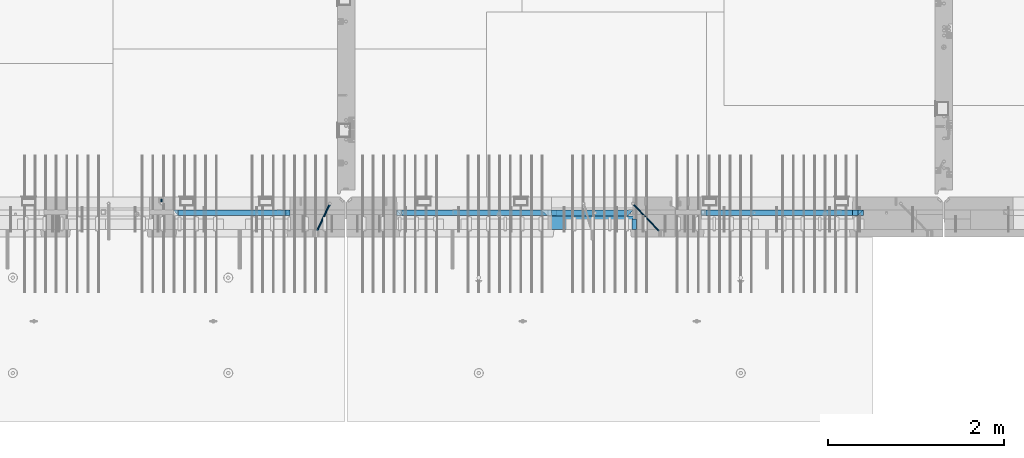
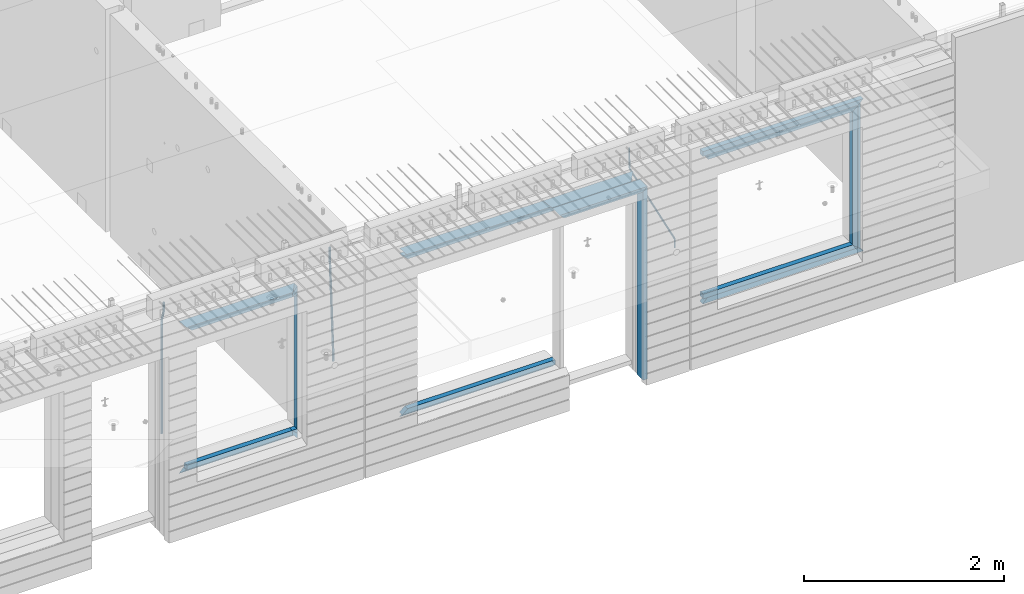
# One storey, part 80 of 309: 22 beams, 3 elements without a shape of their own.
"""IFC2X3 building model written with IfcOpenShell, lengths in millimetres."""

from ifc_helpers import new_model, si_unit, frame, origin_with_axes, place, context, subcontext, project, spatial, faceted_brep, material, type_object, element, aggregate, save


model = new_model("IFC2X3")

# Units and contexts
model_context = context("Model", 3, precision=1e-05, world=origin_with_axes())
body_context = subcontext(model_context, "Body", "Model", "MODEL_VIEW")
ifc_project = project(units=[si_unit("LENGTHUNIT", "METRE", prefix="MILLI"), si_unit("AREAUNIT", "SQUARE_METRE"), si_unit("VOLUMEUNIT", "CUBIC_METRE"), si_unit("MASSUNIT", "GRAM", prefix="KILO"), si_unit("TIMEUNIT", "SECOND"), si_unit("PLANEANGLEUNIT", "RADIAN"), si_unit("SOLIDANGLEUNIT", "STERADIAN"), si_unit("THERMODYNAMICTEMPERATUREUNIT", "DEGREE_CELSIUS"), si_unit("LUMINOUSINTENSITYUNIT", "LUMEN")], contexts=[model_context])

# Site, building, storey
site_placement = place(None, origin_with_axes())
site = spatial("IfcSite", under=ifc_project, at=site_placement, CompositionType="ELEMENT")
building_placement = place(site_placement, origin_with_axes())
building = spatial("IfcBuilding", under=site, at=building_placement, CompositionType="ELEMENT")
storey_placement = place(building_placement, origin_with_axes())
storey = spatial("IfcBuildingStorey", under=building, at=storey_placement, Name="7", CompositionType="ELEMENT", Elevation=0.0)

# Assembly, beams
assembly_1_placement = place(storey_placement, origin_with_axes())
assembly_1 = element("IfcElementAssembly", 1, at=assembly_1_placement, inside=storey, AssemblyPlace="NOTDEFINED", PredefinedType="REINFORCEMENT_UNIT")
ifc_material_1 = material(Name="CONCRETE/C35/45")
beam_type_1 = type_object("IfcBeamType", PredefinedType="NOTDEFINED")
beam_1_placement = place(assembly_1_placement, frame((24034.9998642727, 7815.0, 102140.0), z_axis=(0.0, 0.0, -1.0), x_axis=(1.0, 0.0, 0.0)))
beam_1 = element("IfcBeam", 2, at=beam_1_placement, type_object=beam_type_1, material=ifc_material_1, Name="SK", context=body_context, shape_type="Brep", body=[
    faceted_brep([(70.0000000000164, -35.0, 35.0), (70.0000000000164, 35.0, 35.0), (0.0, -35.0, -35.0), (1039.99961853026, -35.0, -35.0), (980.889062997325, -35.0, 35.0), (980.889062997325, 35.0, 35.0)], [[[0, 1, 2]], [[0, 2, 3, 4]], [[1, 0, 4, 5]], [[2, 1, 5, 3]], [[4, 3, 5]]]),
])
ifc_material_2 = material(Name="TIMBER")
beam_type_2 = type_object("IfcBeamType", Name="50X150", PredefinedType="NOTDEFINED")
beam_2_placement = place(assembly_1_placement, frame((24104.9998642727, 7705.0, 102080.0), z_axis=(0.0, 0.0, -1.0), x_axis=(1.0, 0.0, 0.0)))
beam_2 = element("IfcBeam", 3, at=beam_2_placement, type_object=beam_type_2, material=ifc_material_2, ObjectType="50X150", context=body_context, shape_type="Brep", body=[
    faceted_brep([(50.0000000000036, -75.0, 25.0), (50.0000000000036, 75.0, 25.0), (0.0, 75.0, -25.0), (0.0, -75.0, -25.0), (1009.99961853027, -75.0, -25.0), (959.999618530259, -75.0, 25.0), (959.999618530259, 75.0, 25.0), (1009.99961853027, 75.0, -25.0)], [[[0, 1, 2, 3]], [[0, 3, 4, 5]], [[1, 0, 5, 6]], [[2, 1, 6, 7]], [[3, 2, 7, 4]], [[6, 5, 4, 7]]]),
])

assembly_2_placement = place(storey_placement, origin_with_axes())
assembly_2 = element("IfcElementAssembly", 4, at=assembly_2_placement, inside=storey, AssemblyPlace="NOTDEFINED", PredefinedType="REINFORCEMENT_UNIT")
ifc_material_3 = material()
beam_type_3 = type_object("IfcBeamType", Name="D20", PredefinedType="NOTDEFINED")
beam_3_placement = place(assembly_2_placement, frame((19710.0073333522, 7925.0, 102407.500005872), z_axis=(0.000415599999849905, 0.999999913638203, 4.76000000899737e-07), x_axis=(0.0, 0.0, -1.0)))
beam_3 = element("IfcBeam", 5, at=beam_3_placement, type_object=beam_type_3, material=ifc_material_3, Name="JM20", ObjectType="D20", context=body_context, shape_type="Brep", body=[
    faceted_brep([(0.0, -10.0, 0.0), (-4.19531716033816e-08, -7.07106781186667, -7.07106781187031), (113.248091332178, -7.0710684840451, -7.0710678117357), (113.248091314759, -10.0000006713562, -2.51020537689328e-10), (0.0, 0.0, -10.0), (113.248091374131, -6.72178430249915e-07, -9.99999999986903), (4.196772351861e-08, 7.07106781186303, -7.07106781186667), (113.248091416113, 7.07106713968824, -7.07106781173934), (0.0, 10.0, 0.0), (113.248091433488, 9.99999932782521, 1.30967237055302e-10), (4.196772351861e-08, 7.07106781185939, 7.07106781185939), (113.248091416113, 7.0710671396846, 7.071067811994), (0.0, 0.0, 10.0), (113.248091374131, -6.72174792271107e-07, 10.0000000001273), (-4.19531716033816e-08, -7.07106781187031, 7.07106781185939), (113.248091332178, -7.0710684840451, 7.071067811994), (130.699843527167, -7.06993249763036, -4.33745683788584), (128.538066582521, -9.99900540317321, 2.39499413731755), (131.594536475241, 0.00119355250353692, -7.12624594330919), (130.698046432328, 7.07220300913468, -4.33773834422391), (128.535525107087, 10.0009944322555, 2.39459602660281), (126.373748162892, 7.07192152754578, 9.1270470011732), (125.479055214906, 0.000795477419160306, 11.9158361066184), (126.37554525779, -7.07021397921199, 9.12732850753673), (240.336258550378, -7.05529970173666, 30.8729495437874), (238.174481606227, -9.98437260450009, 37.6054005176375), (241.230951498423, 0.0158263482953771, 28.0841604381058), (240.334461455612, 7.0868358050102, 30.8726680369582), (238.171940130502, 10.0156272283348, 37.6050024077231), (236.010163186409, 7.08655432384694, 44.3374533824244), (235.115470238379, 0.0154282738185429, 47.1262424881097), (236.011960281176, -7.05558118289991, 44.3377348892536), (253.461915329972, -7.05444528127919, 32.9289287376414), (253.46191532613, -9.98337746617108, 39.9999965521893), (253.461915339081, 0.0166225284556276, 29.9999965443676), (253.461915348205, 7.08769034247234, 32.9289287273205), (253.461915352003, 10.0166225357716, 39.9999965370152), (253.461915348293, 7.08769035281148, 47.0710643509774), (253.461915339183, 0.0166225430875784, 49.999996544273), (253.46191533003, -7.05444527093641, 47.0710643613093), (1617.47998045172, -7.05444857276962, 32.9289287369675), (1617.47998044467, -9.98338075699212, 39.9999965504549), (1617.47998046874, 0.0166192374708771, 29.9999965449206), (1617.47998048575, 7.08768705096008, 32.9289287291404), (1617.47998049279, 10.0166192430079, 39.9999965393854), (1617.47998048575, 7.08768705878902, 47.071064352871), (1617.47998046874, 0.0166192485448846, 49.9999965449197), (1617.47998045172, -7.05444856494069, 47.0710643606981)], [[[0, 1, 2, 3]], [[1, 4, 5, 2]], [[4, 6, 7, 5]], [[6, 8, 9, 7]], [[8, 10, 11, 9]], [[10, 12, 13, 11]], [[12, 14, 15, 13]], [[14, 0, 3, 15]], [[14, 12, 10, 8, 6, 4, 1, 0]], [[3, 2, 16, 17]], [[2, 5, 18, 16]], [[5, 7, 19, 18]], [[7, 9, 20, 19]], [[9, 11, 21, 20]], [[11, 13, 22, 21]], [[13, 15, 23, 22]], [[15, 3, 17, 23]], [[17, 16, 24, 25]], [[16, 18, 26, 24]], [[18, 19, 27, 26]], [[19, 20, 28, 27]], [[20, 21, 29, 28]], [[21, 22, 30, 29]], [[22, 23, 31, 30]], [[23, 17, 25, 31]], [[25, 24, 32, 33]], [[24, 26, 34, 32]], [[26, 27, 35, 34]], [[27, 28, 36, 35]], [[28, 29, 37, 36]], [[29, 30, 38, 37]], [[30, 31, 39, 38]], [[31, 25, 33, 39]], [[33, 32, 40, 41]], [[32, 34, 42, 40]], [[34, 35, 43, 42]], [[35, 36, 44, 43]], [[36, 37, 45, 44]], [[37, 38, 46, 45]], [[38, 39, 47, 46]], [[39, 33, 41, 47]], [[42, 43, 44, 45, 46, 47, 41, 40]]]),
])
beam_4_placement = place(assembly_2_placement, frame((21625.0073331492, 7924.99999997881, 102407.5), z_axis=(-0.000415599999849952, -0.999999913638316, 0.0), x_axis=(-6.05680000062309e-05, -4.00000390151988e-09, -0.999999998165759)))
beam_4 = element("IfcBeam", 6, at=beam_4_placement, type_object=beam_type_3, material=ifc_material_3, Name="JM20", ObjectType="D20", context=body_context, shape_type="Brep", body=[
    faceted_brep([(-0.00060564729210455, -9.99999998165731, 0.0), (-0.000428079845733009, -7.07106779890455, -7.07106781186667), (119.575515501536, -7.07830994756296, -7.07106481604933), (119.575337932896, -10.0072421307195, -3.43332612828817e-06), (0.0, 0.0, -10.0), (119.575943836026, -0.00724214867295814, -9.99999700418266), (0.00042843479604926, 7.07106779888636, -7.07106781186303), (119.57637202373, 7.06382565022977, -7.07106481604933), (0.00060564729210455, 9.99999998166459, 3.63797880709171e-12), (119.576549238118, 9.99275783300072, 2.99581552098971e-06), (0.000428079845733009, 7.07106779890819, 7.07106781186667), (119.576371669405, 7.06382565024978, 7.07107080768037), (0.0, 0.0, 10.0), (119.57594333493, -0.00724214864203532, 10.0000029958155), (-0.000428434810601175, -7.07106779888272, 7.07106781186667), (119.575515147211, -7.07830994754295, 7.07107080768037), (123.006973508192, -7.07825951346604, -6.96785036235087), (122.582196132164, -10.0072047447829, 0.090452766209637), (123.182421564867, -0.00718632049392909, -9.89150999405319), (123.005765870272, 7.06387605862983, -6.9678969281922), (122.5804889344, 9.99279518261392, 0.090375952400791), (122.155712218591, 7.06384995171538, 7.14866812117907), (121.980264161975, -0.00722324126036256, 10.0723277528814), (122.156919856599, -7.07828562038412, 7.14871468701676), (235.904703171851, -7.06860422895625, -0.169508357435916), (235.479926262604, -9.99754169577864, 6.88878701985595), (236.080151695453, 0.002465748351824, -3.09317573838871), (235.903496467319, 7.07353134315781, -0.16957042179456), (235.478219724217, 10.0024582304504, 6.88869924890878), (235.053442814489, 7.07352076285679, 13.9469946275131), (234.877994290917, 0.00245078554871725, 16.8706620084649), (235.05464951905, -7.06861480925727, 13.9470566918726), (247.69730842374, 6.49890140729985, 1.5904257279044), (247.708271375333, -0.564091162203113, -1.35790592567901), (246.351191555892, -7.5775885142175, 1.3894260566567), (244.421027918448, -10.4331790195793, 8.22307186000126), (243.04844414418, -7.45809648886643, 15.1399744532118), (243.037481192529, -0.395103919359826, 18.0883061067871), (244.394561011999, 6.61839343264, 15.3409741244495), (246.324724649443, 9.47398393802723, 8.50732832109588), (256.620302657771, 7.90789673379186, 11.9850227549905), (258.892076862918, 4.79603600307382, 5.371853429986), (253.26121545503, 5.26966351612282, 18.3359992487194), (250.782522980895, -1.57322241172369, 20.7044670154446), (250.636209669712, -8.61229127897968, 17.7030097594688), (252.907983874131, -11.724152010418, 11.0898404357176), (256.267071077629, -9.08591879203959, 4.7388639407518), (258.745763551793, -2.24303286420036, 2.37039617402661), (1008.47908473376, -166.485147783689, 337.205828025195), (1005.11999753102, -169.123381001344, 343.556804518913), (1010.95777720789, -159.642261855857, 334.837360258474), (1011.10409051905, -152.60319298859, 337.838817514449), (1008.83231631388, -149.491332257865, 344.451986839456), (1005.47322911114, -152.129565475519, 350.802963333173), (1002.99453663701, -158.972451403351, 353.171431099895), (1002.84822332587, -166.011520270618, 350.169973843918), (1010.17087503639, -166.839152352099, 337.953575170377), (1008.40147312843, -169.810024819315, 345.007169854448), (1011.47638800017, -159.75078038171, 335.066578819891), (1011.55326023143, -152.697181073247, 338.037344110582), (1010.35646101969, -149.810257238067, 345.125637025791), (1008.58705911171, -152.781129705283, 352.179231709861), (1007.28154614793, -159.869501675676, 355.066228060347), (1007.20467391667, -166.923100984135, 352.095462769656), (1012.05411677422, -166.839038287919, 337.953575122971), (1012.05429688386, -169.809803575103, 345.007169762499), (1012.05368737834, -159.750745415844, 335.066578805359), (1012.05326023052, -152.697150789249, 338.037344097996), (1012.05308554815, -149.81015447692, 345.125636983083), (1012.05326565779, -152.780919764096, 352.179231622609), (1012.05369505366, -159.869212636178, 355.066227940223), (1012.05412220149, -166.92280726277, 352.095462647586), (1117.510115663, -166.832651029355, 337.953572468433), (1117.51029577265, -169.803416316539, 345.00716710796), (1117.50968626713, -159.744358157277, 335.06657615082), (1117.50925911931, -152.690763530685, 338.037341443456), (1117.50908443694, -149.803767218353, 345.125634328543), (1117.50926454658, -152.774532505533, 352.17922896807), (1117.50969394245, -159.862825377615, 355.066225285684), (1117.51012109026, -166.916420004207, 352.095459993046)], [[[0, 1, 2, 3]], [[1, 4, 5, 2]], [[4, 6, 7, 5]], [[6, 8, 9, 7]], [[8, 10, 11, 9]], [[10, 12, 13, 11]], [[12, 14, 15, 13]], [[14, 0, 3, 15]], [[14, 12, 10, 8, 6, 4, 1, 0]], [[3, 2, 16, 17]], [[2, 5, 18, 16]], [[5, 7, 19, 18]], [[7, 9, 20, 19]], [[9, 11, 21, 20]], [[11, 13, 22, 21]], [[13, 15, 23, 22]], [[15, 3, 17, 23]], [[17, 16, 24, 25]], [[16, 18, 26, 24]], [[18, 19, 27, 26]], [[19, 20, 28, 27]], [[20, 21, 29, 28]], [[21, 22, 30, 29]], [[22, 23, 31, 30]], [[23, 17, 25, 31]], [[26, 27, 32, 33]], [[24, 26, 33, 34]], [[25, 24, 34, 35]], [[31, 25, 35, 36]], [[30, 31, 36, 37]], [[29, 30, 37, 38]], [[28, 29, 38, 39]], [[27, 28, 39, 32]], [[39, 40, 41, 32]], [[38, 42, 40, 39]], [[37, 43, 42, 38]], [[36, 44, 43, 37]], [[35, 45, 44, 36]], [[34, 46, 45, 35]], [[33, 47, 46, 34]], [[32, 41, 47, 33]], [[45, 46, 48, 49]], [[46, 47, 50, 48]], [[47, 41, 51, 50]], [[41, 40, 52, 51]], [[40, 42, 53, 52]], [[42, 43, 54, 53]], [[43, 44, 55, 54]], [[44, 45, 49, 55]], [[49, 48, 56, 57]], [[48, 50, 58, 56]], [[50, 51, 59, 58]], [[51, 52, 60, 59]], [[52, 53, 61, 60]], [[53, 54, 62, 61]], [[54, 55, 63, 62]], [[55, 49, 57, 63]], [[57, 56, 64, 65]], [[56, 58, 66, 64]], [[58, 59, 67, 66]], [[59, 60, 68, 67]], [[60, 61, 69, 68]], [[61, 62, 70, 69]], [[62, 63, 71, 70]], [[63, 57, 65, 71]], [[65, 64, 72, 73]], [[64, 66, 74, 72]], [[66, 67, 75, 74]], [[67, 68, 76, 75]], [[68, 69, 77, 76]], [[69, 70, 78, 77]], [[70, 71, 79, 78]], [[71, 65, 73, 79]], [[74, 75, 76, 77, 78, 79, 73, 72]]]),
])

# Beam
beam_5_placement = place(assembly_1_placement, frame((25075.0293329014, 7924.99999993642, 102407.5), z_axis=(-0.000415599999849952, -0.999999913638316, 0.0), x_axis=(-0.000242263999929879, 0.0, -0.999999970654077)))
beam_5 = element("IfcBeam", 7, at=beam_5_placement, type_object=beam_type_3, material=ifc_material_3, Name="JM20", ObjectType="D20", context=body_context, shape_type="Brep", body=[
    faceted_brep([(-0.00060564729210455, -9.99999998165731, 0.0), (-0.000428079845733009, -7.07106779890455, -7.07106781186667), (119.575515501536, -7.07830994756296, -7.07106481604933), (119.575337932896, -10.0072421307195, -3.43332612828817e-06), (0.0, 0.0, -10.0), (119.575943836026, -0.00724214867295814, -9.99999700418266), (0.00042843479604926, 7.07106779888636, -7.07106781186303), (119.57637202373, 7.06382565022977, -7.07106481604933), (0.00060564729210455, 9.99999998166459, 3.63797880709171e-12), (119.576549238118, 9.99275783300072, 2.99581552098971e-06), (0.000428079845733009, 7.07106779890819, 7.07106781186667), (119.576371669405, 7.06382565024978, 7.07107080768037), (0.0, 0.0, 10.0), (119.57594333493, -0.00724214864203532, 10.0000029958155), (-0.000428434810601175, -7.07106779888272, 7.07106781186667), (119.575515147211, -7.07830994754295, 7.07107080768037), (123.008274907785, -7.07795567963694, -6.96780325792497), (122.584029738471, -10.0069316327917, 0.0905081323508057), (123.182440752484, -0.00686994861462153, -9.89150922917906), (123.004503280346, 7.06417944043824, -6.96794247666548), (122.578695849254, 9.99306765562687, 0.0903112464729929), (122.15445067735, 7.0640917031651, 7.14862263591931), (121.980284832651, -0.0069940278553986, 10.072328607177), (122.158222304832, -7.07804341691372, 7.14876185467801), (233.088395941915, -7.04853267872386, -0.33914435535371), (232.664150764584, -9.97750862893736, 6.71916703474017), (233.262561786629, 0.0225530520438042, -3.26285032724809), (233.08462431423, 7.09360244138225, -0.339283575355694), (232.658816882788, 10.0224906572403, 6.71897014756632), (232.234571710651, 7.09351470543697, 13.777281537301), (232.060405865923, 0.0224289746693103, 16.7009875091953), (232.238343338337, -7.04862041468004, 13.7774207573038), (248.070459246126, -5.60737147376494, 1.85103242021069), (247.013897852143, -8.59717146491312, 8.81690765643543), (244.865343898215, -5.8339984379636, 15.6233189364948), (242.883391151001, 1.06351832306973, 18.2831628436061), (242.22904064988, 8.05490704629119, 15.2383388907911), (243.285602043848, 11.0447070374539, 8.27246365456904), (245.434155997835, 8.28153401051895, 1.46605237452331), (247.416108745019, 1.38401724946743, -1.19379153259433), (260.512945877912, 5.37327174938764, 3.16696371259513), (261.933955342625, -1.38459511741894, 6.46705632785779), (256.86166640259, 11.762316953962, 5.27098446848322), (253.118986913221, 14.0399244660766, 11.5466117722399), (251.477318295016, 10.8719026949148, 18.3176682617204), (252.898327759729, 4.11403582813364, 21.6177608769931), (256.54960723508, -2.27500937642981, 19.5137401211105), (260.292286730517, -4.55261688891915, 13.2381128181169), (1011.6899267952, 318.016952836686, 337.688913324002), (1010.04825817693, 314.848931065488, 344.459969813425), (1010.26891733034, 324.774819703332, 334.388820708672), (1006.61763785462, 331.163864907652, 336.492841464405), (1002.87495836492, 333.441472419578, 342.76846876801), (1001.23328974665, 330.273450648383, 349.539525257433), (1002.6542992115, 323.515583781733, 352.839617872763), (1006.30557868723, 317.12653857741, 350.73559711703), (1012.11607330808, 318.198494379605, 337.877173297548), (1011.23010097447, 315.352404773395, 344.982075913254), (1011.34812648257, 325.234570724882, 334.865586047124), (1009.37611333313, 332.338995712049, 337.711461129013), (1007.35521241752, 335.350093536494, 344.747723517063), (1006.46924008391, 332.504003930284, 351.85262613277), (1007.23718690944, 325.467927585003, 354.864213383194), (1009.20920005886, 318.363502597836, 352.018338301305), (1012.61607329341, 318.198615511596, 337.877173247205), (1012.61676345688, 315.352740711776, 344.982075773638), (1012.61436835937, 325.234877489685, 334.865585919631), (1012.61264738202, 332.339779807688, 337.71146080314), (1012.61191848651, 335.351367047057, 344.747722987787), (1012.61260864999, 332.505492247237, 351.852625514221), (1012.61431358402, 325.469230269144, 354.864212841793), (1012.61603456138, 318.364327951142, 352.018337958285), (1117.42297412557, 318.224006449098, 337.87716269464), (1117.42366428903, 315.378131649279, 344.982065221072), (1117.42126919153, 325.260268427191, 334.865575367066), (1117.41954821418, 332.365170745194, 337.711450250575), (1117.41881931867, 335.376757984559, 344.747712435222), (1117.41950948215, 332.530883184736, 351.852614961655), (1117.42121441617, 325.494621206646, 354.864202289227), (1117.42293539354, 318.389718888644, 352.018327405719)], [[[0, 1, 2, 3]], [[1, 4, 5, 2]], [[4, 6, 7, 5]], [[6, 8, 9, 7]], [[8, 10, 11, 9]], [[10, 12, 13, 11]], [[12, 14, 15, 13]], [[14, 0, 3, 15]], [[14, 12, 10, 8, 6, 4, 1, 0]], [[3, 2, 16, 17]], [[2, 5, 18, 16]], [[5, 7, 19, 18]], [[7, 9, 20, 19]], [[9, 11, 21, 20]], [[11, 13, 22, 21]], [[13, 15, 23, 22]], [[15, 3, 17, 23]], [[17, 16, 24, 25]], [[16, 18, 26, 24]], [[18, 19, 27, 26]], [[19, 20, 28, 27]], [[20, 21, 29, 28]], [[21, 22, 30, 29]], [[22, 23, 31, 30]], [[23, 17, 25, 31]], [[25, 24, 32, 33]], [[31, 25, 33, 34]], [[30, 31, 34, 35]], [[29, 30, 35, 36]], [[28, 29, 36, 37]], [[27, 28, 37, 38]], [[26, 27, 38, 39]], [[24, 26, 39, 32]], [[39, 40, 41, 32]], [[38, 42, 40, 39]], [[37, 43, 42, 38]], [[36, 44, 43, 37]], [[35, 45, 44, 36]], [[34, 46, 45, 35]], [[33, 47, 46, 34]], [[32, 41, 47, 33]], [[47, 41, 48, 49]], [[41, 40, 50, 48]], [[40, 42, 51, 50]], [[42, 43, 52, 51]], [[43, 44, 53, 52]], [[44, 45, 54, 53]], [[45, 46, 55, 54]], [[46, 47, 49, 55]], [[49, 48, 56, 57]], [[48, 50, 58, 56]], [[50, 51, 59, 58]], [[51, 52, 60, 59]], [[52, 53, 61, 60]], [[53, 54, 62, 61]], [[54, 55, 63, 62]], [[55, 49, 57, 63]], [[57, 56, 64, 65]], [[56, 58, 66, 64]], [[58, 59, 67, 66]], [[59, 60, 68, 67]], [[60, 61, 69, 68]], [[61, 62, 70, 69]], [[62, 63, 71, 70]], [[63, 57, 65, 71]], [[65, 64, 72, 73]], [[64, 66, 74, 72]], [[66, 67, 75, 74]], [[67, 68, 76, 75]], [[68, 69, 77, 76]], [[69, 70, 78, 77]], [[70, 71, 79, 78]], [[71, 65, 73, 79]], [[74, 75, 76, 77, 78, 79, 73, 72]]]),
])

beam_type_4 = type_object("IfcBeamType", PredefinedType="NOTDEFINED")
beam_6_placement = place(assembly_2_placement, frame((19845.0006272121, 7820.0, 102145.0), z_axis=(0.0, 0.0, -1.0), x_axis=(1.0, 0.0, 0.0)))
beam_6 = element("IfcBeam", 8, at=beam_6_placement, type_object=beam_type_4, material=ifc_material_1, Name="SK", context=body_context, shape_type="Brep", body=[
    faceted_brep([(0.0, -30.0, -30.0), (49.817662327685, -30.0, 30.0), (49.817662327685, 30.0, 30.0), (1329.99923706055, -30.0, -30.0), (1280.18157473286, -30.0, 30.0), (1280.18157473286, 30.0, 30.0)], [[[0, 1, 2]], [[1, 0, 3, 4]], [[2, 1, 4, 5]], [[0, 2, 5, 3]], [[4, 3, 5]]]),
])

beam_7_placement = place(assembly_2_placement, frame((19905.0006272121, 7820.0, 102085.0), z_axis=(0.0, 0.0, -1.0), x_axis=(1.0, 0.0, 0.0)))
beam_7 = element("IfcBeam", 9, at=beam_7_placement, type_object=beam_type_4, material=ifc_material_1, Name="SK", context=body_context, shape_type="Brep", body=[
    faceted_brep([(0.0, -30.0, -30.0), (53.0959879499314, -30.0, 24.0540540540678), (54.6888675884184, 30.0, 25.6756756756804), (0.0, 30.0, -30.0), (1269.99923706055, -30.0, -30.0), (1211.91971158142, -30.0, 24.0540540540533), (1210.17732581704, 30.0, 25.6756756756804), (1269.99923706055, 30.0, -30.0)], [[[0, 1, 2, 3]], [[1, 0, 4, 5]], [[2, 1, 5, 6]], [[3, 2, 6, 7]], [[0, 3, 7, 4]], [[6, 5, 4, 7]]]),
])

beam_8_placement = place(assembly_2_placement, frame((21144.9998642727, 7820.0, 102175.0), z_axis=(-1.0, 3.00000001838171e-08, 0.0), x_axis=(0.0, 0.0, -1.0)))
beam_8 = element("IfcBeam", 10, at=beam_8_placement, type_object=beam_type_4, material=ifc_material_1, Name="SK", context=body_context, shape_type="Brep", body=[
    faceted_brep([(1740.94594594595, -30.0, 30.0), (1739.32432432432, 30.0, 30.0), (1739.32432432432, 30.0, -24.3243243243269), (1740.94594594595, -30.0, -25.9459459459504), (115.67567567568, 30.0, -24.3243243243269), (114.054054054053, -30.0, -25.9459459459504), (115.67567567568, 30.0, 30.0), (114.054054054053, -30.0, 30.0), (72.2635272671032, 30.0, 30.0), (72.2635272671032, -30.0, 30.0), (0.0, 30.0, -30.0), (0.0, -30.0, -30.0), (1855.0, -30.0, -30.0), (1782.73647273288, -30.0, 30.0), (1782.73647273287, 30.0, 30.0), (1855.0, 30.0, -30.0)], [[[0, 1, 2, 3]], [[3, 2, 4, 5]], [[5, 4, 6, 7]], [[7, 6, 8, 9]], [[10, 11, 9, 8]], [[0, 3, 5, 7, 9, 11, 12, 13]], [[1, 0, 13, 14]], [[10, 8, 6, 4, 2, 1, 14, 15]], [[15, 12, 11, 10]], [[15, 14, 13, 12]]]),
])

beam_9_placement = place(assembly_2_placement, frame((21174.9998642727, 7820.0, 100350.0), z_axis=(0.0, 0.0, 1.0), x_axis=(-1.0, 3.00000001838171e-08, 0.0)))
beam_9 = element("IfcBeam", 11, at=beam_9_placement, type_object=beam_type_4, material=ifc_material_1, Name="SK", context=body_context, shape_type="Brep", body=[
    faceted_brep([(1280.18157473286, -30.0, 30.0), (1329.99923706055, -30.0, -30.0), (1280.18157473286, 30.0, 30.0), (0.0, -30.0, -30.0), (49.817662327685, 30.0, 30.0), (49.817662327685, -30.0, 30.0)], [[[0, 1, 2]], [[3, 4, 2, 1]], [[4, 5, 0, 2]], [[5, 3, 1, 0]], [[3, 5, 4]]]),
])

beam_10_placement = place(assembly_2_placement, frame((21174.9998642727, 7820.0, 100410.0), z_axis=(0.0, 0.0, 1.0), x_axis=(-1.0, 3.00000001838171e-08, 0.0)))
beam_10 = element("IfcBeam", 12, at=beam_10_placement, type_object=beam_type_4, material=ifc_material_1, Name="SK", context=body_context, shape_type="Brep", body=[
    faceted_brep([(1269.99923706055, -30.0, -30.0), (1269.99923706055, 30.0, -30.0), (1269.99923706055, 30.0, 25.6756756756804), (1269.99923706055, -30.0, 24.0540540540678), (0.0, -30.0, -30.0), (0.0, 30.0, -30.0), (59.8219112435072, 30.0, 25.6756756756804), (58.0795254791192, -30.0, 24.0540540540533)], [[[0, 1, 2, 3]], [[4, 5, 1, 0]], [[2, 1, 5, 6]], [[3, 2, 6, 7]], [[0, 3, 7, 4]], [[6, 5, 4, 7]]]),
])

beam_11_placement = place(assembly_1_placement, frame((22384.9998642751, 7820.0, 102145.0), z_axis=(0.0, 0.0, -1.0), x_axis=(1.0, 0.0, 0.0)))
beam_11 = element("IfcBeam", 13, at=beam_11_placement, type_object=beam_type_4, material=ifc_material_1, Name="SK", context=body_context, shape_type="Brep", body=[
    faceted_brep([(1820.00000000026, -30.0, 30.0), (1820.00000000026, -30.0, -30.0), (1820.00000000026, 30.0, 30.0), (49.817662327685, -30.0, 30.0), (0.0, -30.0, -30.0), (49.817662327685, 30.0, 30.0)], [[[0, 1, 2]], [[1, 0, 3, 4]], [[2, 1, 4, 5]], [[0, 2, 5, 3]], [[4, 3, 5]]]),
])

beam_12_placement = place(assembly_1_placement, frame((22384.9998642751, 7820.0, 102085.0), z_axis=(0.0, 0.0, -1.0), x_axis=(1.0, 0.0, 0.0)))
beam_12 = element("IfcBeam", 14, at=beam_12_placement, type_object=beam_type_4, material=ifc_material_1, Name="SK", context=body_context, shape_type="Brep", body=[
    faceted_brep([(1820.00000000026, -30.0, -30.0), (1820.00000000026, 30.0, -30.0), (1820.00000000026, 30.0, 25.6756756756804), (1820.00000000026, -30.0, 24.0540540540678), (59.8219112435072, 30.0, 25.6756756756804), (58.0795254791192, -30.0, 24.0540540540533), (0.0, -30.0, -30.0), (0.0, 30.0, -30.0)], [[[0, 1, 2, 3]], [[3, 2, 4, 5]], [[0, 3, 5, 6]], [[6, 7, 1, 0]], [[2, 1, 7, 4]], [[4, 7, 6, 5]]]),
])

beam_13_placement = place(assembly_1_placement, frame((24144.9998642753, 7820.0, 100150.0), z_axis=(0.0, 0.0, 1.0), x_axis=(-1.0, 3.00000001838171e-08, 0.0)))
beam_13 = element("IfcBeam", 15, at=beam_13_placement, type_object=beam_type_4, material=ifc_material_1, Name="SK", context=body_context, shape_type="Brep", body=[
    faceted_brep([(0.0, -30.0, 30.0), (-5.28234522789717e-09, 30.0, 30.0), (0.0, -30.0, -30.0), (1710.18233767259, -30.0, 30.0), (1710.18233767259, 30.0, 30.0), (1760.00000000026, -30.0, -30.0)], [[[0, 1, 2]], [[1, 0, 3, 4]], [[2, 1, 4, 5]], [[0, 2, 5, 3]], [[4, 3, 5]]]),
])

beam_14_placement = place(assembly_1_placement, frame((24144.9998642753, 7820.0, 100210.0), z_axis=(0.0, 0.0, 1.0), x_axis=(-1.0, 3.00000001838171e-08, 0.0)))
beam_14 = element("IfcBeam", 16, at=beam_14_placement, type_object=beam_type_4, material=ifc_material_1, Name="SK", context=body_context, shape_type="Brep", body=[
    faceted_brep([(0.0, 30.0, -30.0), (0.0, -30.0, -30.0), (0.0, -30.0, 24.0540540540678), (0.0, 30.0, 25.6756756756804), (1700.17808875675, 30.0, 25.6756756756804), (1760.00000000026, 30.0, -30.0), (1760.00000000026, -30.0, -30.0), (1701.92047452114, -30.0, 24.0540540540533)], [[[0, 1, 2, 3]], [[0, 3, 4, 5]], [[1, 0, 5, 6]], [[2, 1, 6, 7]], [[3, 2, 7, 4]], [[6, 5, 4, 7]]]),
])

# Assembly, beams
assembly_3_placement = place(storey_placement, origin_with_axes())
assembly_3 = element("IfcElementAssembly", 17, at=assembly_3_placement, inside=storey, AssemblyPlace="NOTDEFINED", PredefinedType="REINFORCEMENT_UNIT")
beam_15_placement = place(assembly_3_placement, frame((25845.0006272121, 7820.0, 102145.0), z_axis=(0.0, 0.0, -1.0), x_axis=(1.0, 0.0, 0.0)))
beam_15 = element("IfcBeam", 18, at=beam_15_placement, type_object=beam_type_4, material=ifc_material_1, Name="SK", context=body_context, shape_type="Brep", body=[
    faceted_brep([(0.0, -30.0, -30.0), (0.0, -30.0, 30.0), (-5.28234522789717e-09, 30.0, 30.0), (0.0, 30.0, -30.0), (1849.99885559082, -30.0, -30.0), (1789.99885559081, -30.0, 30.0), (1789.99885559081, 30.0, 30.0), (1849.99885559082, 30.0, -30.0)], [[[0, 1, 2, 3]], [[1, 0, 4, 5]], [[2, 1, 5, 6]], [[3, 2, 6, 7]], [[0, 3, 7, 4]], [[6, 5, 4, 7]]]),
])
beam_16_placement = place(assembly_3_placement, frame((25905.0006272121, 7820.0, 102085.0), z_axis=(0.0, 0.0, -1.0), x_axis=(1.0, 0.0, 0.0)))
beam_16 = element("IfcBeam", 19, at=beam_16_placement, type_object=beam_type_4, material=ifc_material_1, Name="SK", context=body_context, shape_type="Brep", body=[
    faceted_brep([(1665.94480153677, -30.0, 24.0540540540533), (1664.32317991515, 30.0, 25.6756756756804), (0.0, 30.0, 25.6756756756804), (0.0, -30.0, 24.0540540540678), (0.0, 30.0, -30.0), (0.0, -30.0, -30.0), (1729.99885559082, -30.0, -30.0), (1665.94480153677, -30.0, 24.9034748914419), (1664.32317991515, 30.0, 26.293436281092), (1729.99885559082, 30.0, -30.0)], [[[0, 1, 2, 3]], [[4, 5, 3, 2]], [[0, 3, 5, 6, 7]], [[1, 0, 7, 8]], [[4, 2, 1, 8, 9]], [[5, 4, 9, 6]], [[8, 7, 6, 9]]]),
])
beam_17_placement = place(assembly_3_placement, frame((27664.9994828029, 7820.0, 102175.0), z_axis=(-1.0, 3.00000001838171e-08, 0.0), x_axis=(0.0, 0.0, -1.0)))
beam_17 = element("IfcBeam", 20, at=beam_17_placement, type_object=beam_type_4, material=ifc_material_1, Name="SK", context=body_context, shape_type="Brep", body=[
    faceted_brep([(60.0000000000073, 30.0, 30.0), (0.0, -30.0, -30.0), (60.0000000000073, -30.0, 30.0), (1855.0, -30.0, -30.0), (1795.00000000001, -30.0, 30.0), (1795.00000000001, 30.0, 30.0)], [[[0, 1, 2]], [[3, 4, 2, 1]], [[4, 5, 0, 2]], [[5, 3, 1, 0]], [[4, 3, 5]]]),
])
beam_18_placement = place(assembly_3_placement, frame((27694.9994828029, 7820.0, 100350.0), z_axis=(0.0, 0.0, 1.0), x_axis=(-1.0, 3.00000001838171e-08, 0.0)))
beam_18 = element("IfcBeam", 21, at=beam_18_placement, type_object=beam_type_4, material=ifc_material_1, Name="SK", context=body_context, shape_type="Brep", body=[
    faceted_brep([(1849.99885559082, 30.0, -30.0), (1800.18119326315, 30.0, 30.0), (1800.18119326315, -30.0, 30.0), (1849.99885559082, -30.0, -30.0), (0.0, -30.0, -30.0), (0.0, 30.0, -30.0), (60.0000000000073, 30.0, 30.0), (60.0000000000073, -30.0, 30.0)], [[[0, 1, 2, 3]], [[4, 5, 0, 3]], [[1, 0, 5, 6]], [[2, 1, 6, 7]], [[3, 2, 7, 4]], [[6, 5, 4, 7]]]),
])
beam_19_placement = place(assembly_3_placement, frame((27634.9994828029, 7820.0, 100410.0), z_axis=(0.0, 0.0, 1.0), x_axis=(-1.0, 3.00000001838171e-08, 0.0)))
beam_19 = element("IfcBeam", 22, at=beam_19_placement, type_object=beam_type_4, material=ifc_material_1, Name="SK", context=body_context, shape_type="Brep", body=[
    faceted_brep([(1785.94885559082, 30.0, 30.0), (1784.32432432432, 30.0, 30.0), (1785.94885559082, -30.0, 30.0), (1785.94885559082, -30.0, 24.0540519302303), (1784.32432432433, 30.0, 25.6756756756804), (65.6756756756768, 30.0, 25.6756756756804), (64.0540540540533, -30.0, 24.0540540540533), (1785.94885559082, -30.0, -30.0), (1785.94885559082, 30.0, -30.0), (0.0, -30.0, -30.0), (0.0, 30.0, -30.0), (65.6756756756768, 30.0, 26.293436281092), (64.0540540540533, -30.0, 24.9034748914419)], [[[0, 1, 2]], [[3, 4, 5, 6]], [[1, 4, 3, 2]], [[7, 8, 0, 2, 3]], [[8, 7, 9, 10]], [[5, 4, 1, 0, 8, 10, 11]], [[6, 5, 11, 12]], [[7, 3, 6, 12, 9]], [[9, 12, 11, 10]]]),
])

# Beam
beam_type_5 = type_object("IfcBeamType", PredefinedType="NOTDEFINED")
beam_20_placement = place(assembly_2_placement, frame((21139.9998642727, 7820.0, 102115.0), z_axis=(-1.0, 3.00000001838171e-08, 0.0), x_axis=(0.0, 0.0, -1.0)))
beam_20 = element("IfcBeam", 23, at=beam_20_placement, type_object=beam_type_5, material=ifc_material_1, Name="SK", context=body_context, shape_type="Brep", body=[
    faceted_brep([(1680.94594594595, -30.0, -30.9459459459504), (1679.32432432432, 30.0, -29.3243243243269), (55.6756756756804, 30.0, -29.3243243243269), (54.0540540540533, -30.0, -30.9459459459504), (55.6756756756804, 30.0, 24.8219112435145), (54.0540540540533, -30.0, 23.0795254791374), (0.0, 30.0, -35.0), (0.0, -30.0, -35.0), (1735.0, -30.0, -35.0), (1680.94594594595, -30.0, 23.0795254791337), (1679.32432432432, 30.0, 24.8219112435145), (1735.0, 30.0, -35.0)], [[[0, 1, 2, 3]], [[3, 2, 4, 5]], [[4, 6, 7, 5]], [[0, 3, 5, 7, 8, 9]], [[1, 0, 9, 10]], [[6, 4, 2, 1, 10, 11]], [[11, 8, 7, 6]], [[10, 9, 8, 11]]]),
])

aggregate(assembly_2, [beam_3, beam_4, beam_6, beam_7, beam_8, beam_20, beam_9, beam_10])

beam_21_placement = place(assembly_3_placement, frame((27599.9994828029, 7820.0, 102115.0), z_axis=(-1.0, 3.00000001838171e-08, 0.0), x_axis=(0.0, 0.0, -1.0)))
beam_21 = element("IfcBeam", 24, at=beam_21_placement, type_object=beam_type_5, material=ifc_material_1, Name="SK", context=body_context, shape_type="Brep", body=[
    faceted_brep([(0.0, -30.0, -35.0), (54.9034748914273, -30.0, 29.0540540540533), (56.2934362811066, 30.0, 30.6756756756768), (0.0, 30.0, -35.0), (1735.0, -30.0, -35.0), (1680.09652510857, -30.0, 29.0540540540533), (1678.70656371891, 30.0, 30.6756756756768), (1735.0, 30.0, -35.0)], [[[0, 1, 2, 3]], [[1, 0, 4, 5]], [[2, 1, 5, 6]], [[3, 2, 6, 7]], [[7, 4, 0, 3]], [[4, 7, 6, 5]]]),
])

aggregate(assembly_3, [beam_15, beam_16, beam_17, beam_21, beam_18, beam_19])

beam_type_6 = type_object("IfcBeamType", Name="50X120", PredefinedType="NOTDEFINED")
beam_22_placement = place(assembly_1_placement, frame((25089.9994828029, 7690.0, 102105.0), z_axis=(-1.0, 3.00000001838171e-08, 0.0), x_axis=(0.0, 0.0, -1.0)))
beam_22 = element("IfcBeam", 25, at=beam_22_placement, type_object=beam_type_6, material=ifc_material_2, ObjectType="50X120", context=body_context, shape_type="Brep", body=[
    faceted_brep([(2345.0, -60.0, 25.0), (2345.0, -60.0, -25.0), (2345.0, 60.0, -25.0), (2345.0, 60.0, 25.0), (0.0, -60.0, -25.0), (0.0, 60.0, -25.0), (50.0000000000036, 60.0, 25.0), (50.0000000000036, -60.0, 25.0)], [[[0, 1, 2, 3]], [[4, 5, 2, 1]], [[3, 2, 5, 6]], [[0, 3, 6, 7]], [[1, 0, 7, 4]], [[5, 4, 7, 6]]]),
])

aggregate(assembly_1, [beam_5, beam_11, beam_12, beam_13, beam_14, beam_1, beam_2, beam_22])

save(model, "model.ifc")
